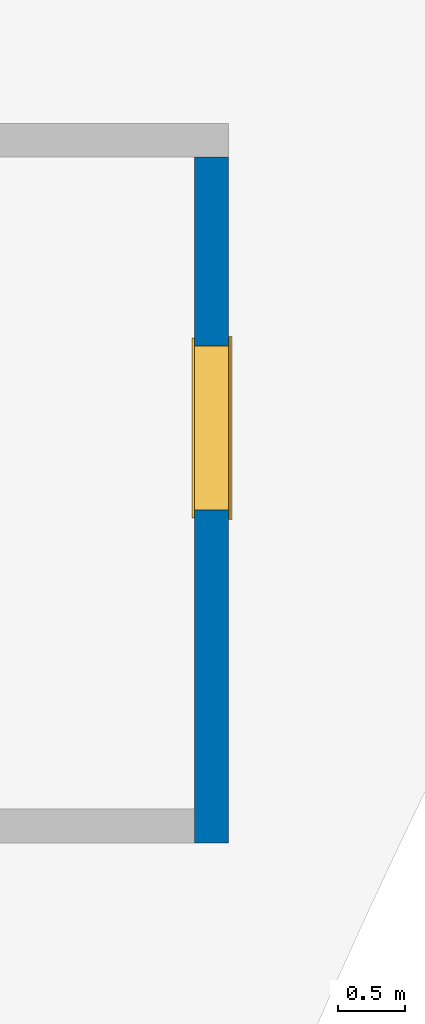
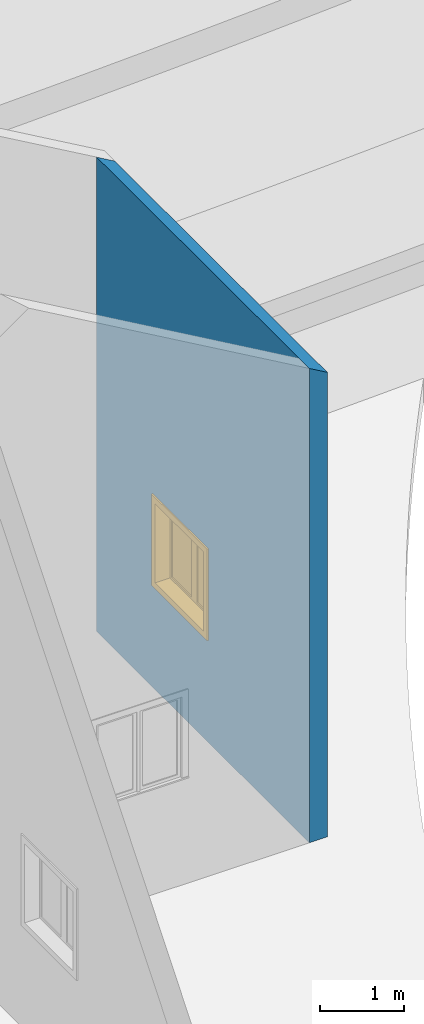
# One storey, part 11 of 39: 1 wall, 1 window, 1 opening.
"""IFC2X3 building model written with IfcOpenShell, lengths in millimetres."""

from ifc_helpers import new_model, entity, si_unit, converted_unit, derived_unit, direction, frame, frame_2d, origin, place, context, subcontext, project, spatial, polyline, rectangle, outline, extrude, clip, bounded_halfspace, source, transform, mapped, material, material_list, layer, layer_set, layer_usage, type_object, type_shapes, element, fill, save


model = new_model("IFC2X3")

# Units and contexts
model_context = context("Model", 3, precision=1e-06, world=origin(), true_north=direction((2.0, 6.12303176911189e-17, 1.0)))
context_of_model = context(None, 3, precision=1e-06, world=origin(), true_north=direction((2.0, 6.12303176911189e-17, 1.0)))
body_context = subcontext(model_context, "Body", "Model", "MODEL_VIEW")
ifc_project = project(units=[si_unit("LENGTHUNIT", "METRE", prefix="MILLI"), si_unit("AREAUNIT", "SQUARE_METRE", prefix="MILLI"), si_unit("VOLUMEUNIT", "CUBIC_METRE", prefix="MILLI"), converted_unit("PLANEANGLEUNIT", "DEGREE", entity("IfcRatioMeasure", 0.0174532925199433), si_unit("PLANEANGLEUNIT", "RADIAN"), dimensions=[0, 0, 0, 0, 0, 0, 0]), si_unit("MASSUNIT", "GRAM", prefix="KILO"), si_unit("TIMEUNIT", "SECOND"), si_unit("THERMODYNAMICTEMPERATUREUNIT", "KELVIN"), derived_unit("THERMALTRANSMITTANCEUNIT", [(si_unit("MASSUNIT", "GRAM", prefix="KILO"), 1), (si_unit("THERMODYNAMICTEMPERATUREUNIT", "KELVIN"), -1), (si_unit("TIMEUNIT", "SECOND"), -3)]), derived_unit("VOLUMETRICFLOWRATEUNIT", [(si_unit("LENGTHUNIT", "METRE"), 3), (si_unit("TIMEUNIT", "SECOND"), -1)])], contexts=[model_context, context_of_model])

# Site, building, storey
site_placement = place(None, origin())
site = spatial("IfcSite", under=ifc_project, at=site_placement, CompositionType="ELEMENT")
building_placement = place(site_placement, origin())
building = spatial("IfcBuilding", under=site, at=building_placement, CompositionType="ELEMENT")
storey_placement = place(building_placement, frame((0.0, 0.0, 4000.0)))
storey = spatial("IfcBuildingStorey", under=building, at=storey_placement, Name="Level 2", CompositionType="ELEMENT", Elevation=4000.0)

# Wall, opening, window
ifc_material_1 = material(Name="Concrete - Cast In Situ")
ifc_layer = layer(ifc_material_1, 250.0)
ifc_layer_set = layer_set([ifc_layer], Name="Basic Wall:Structure wall")
ifc_layer_usage = layer_usage(ifc_layer_set, "AXIS2", "NEGATIVE", 125.0)
wall_type = type_object("IfcWallType", Name="Basic Wall:Structure wall", PredefinedType="STANDARD", material=ifc_layer_set)
wall_placement = place(storey_placement, frame((-312846.196209224, 247689.404995702, 362.0), z_axis=(0.0, 0.0, 1.0), x_axis=(0.0, 1.0, 0.0)))
wall = element("IfcWallStandardCase", 1, at=wall_placement, inside=storey, type_object=wall_type, material=ifc_layer_usage, Name="Basic Wall:Structure wall", ObjectType="Basic Wall:Structure wall", context=body_context, shape_type="Clipping", body=[
    clip(extrude(rectangle(XDim=5088.12506521643, YDim=249.999999999978, at=frame_2d((2544.06253260822, 0.0), x_axis=(-1.0, 0.0))), origin(), (0.0, 0.0, 1.0), 8000.0), bounded_halfspace(frame((0.0, -125.0, 6782.33756729738), z_axis=(0.0, -0.499999999999959, 0.866025403784462), x_axis=(1.0, 0.0, 0.0)), False, frame((0.0, -125.0, 6782.33756729738)), polyline([(0.0, 0.0), (5088.12506521643, 0.0), (5088.12506521643, 250.0), (250.0, 250.0), (0.0, 250.0), (0.0, 0.0)]))),
])
opening_placement = place(wall_placement, frame((3688.12506521644, 125.0, 1553.0)))
opening = element("IfcOpeningElement", 2, at=opening_placement, cuts=wall, Name="M_Casement Dbl with Trim:1220 x 1220mm:1220 x 1220mm:1", ObjectType="Opening", context=body_context, shape_type="SweptSolid", body=[
    extrude(rectangle(XDim=1220.0, YDim=1220.0, at=frame_2d((610.0, 610.0), x_axis=(-1.0, 0.0))), frame((0.0, 0.0, 0.0), z_axis=(0.0, -1.0, 0.0), x_axis=(0.0, 0.0, 1.0)), (0.0, 0.0, 1.0), 250.0),
])
ifc_material_2 = material(Name="Glass")
ifc_material_3 = material(Name="Sash")
ifc_material_4 = material(Name="Trim")
ifc_material_list_1 = material_list([ifc_material_2, ifc_material_3, ifc_material_4])
ifc_material_list_2 = material_list([ifc_material_2, ifc_material_3, ifc_material_4])
window_style = type_object("IfcWindowStyle", Name="1220 x 1220mm", ConstructionType="NOTDEFINED", OperationType="NOTDEFINED", ParameterTakesPrecedence=False, Sizeable=False, material=ifc_material_list_2)
shared_shape = source(origin(), body_context, "Body", "SweptSolid", [
    extrude(rectangle(XDim=482.999999999998, YDim=12.7, at=frame_2d((0.0, -1.68753899743024e-14), x_axis=(1.0, 0.0))), frame((305.0, 246.875, 63.5000000000002), z_axis=(0.0, 0.0, 1.0), x_axis=(-1.0, 0.0, 0.0)), (0.0, 0.0, 1.0), 1093.0),
    extrude(outline(polyline([(-285.949999999999, -590.950000000002), (285.949999999999, -590.950000000002), (285.949999999999, 590.950000000003), (-285.949999999999, 590.950000000003), (-285.949999999999, -590.950000000002)]), holes=[polyline([(-241.499999999998, -546.500000000003), (-241.499999999998, 546.500000000002), (241.5, 546.500000000002), (241.5, -546.500000000003), (-241.499999999998, -546.500000000003)])]), frame((305.0, 269.1, 610.0), z_axis=(0.0, -1.0, 0.0), x_axis=(-1.0, 0.0, 0.0)), (0.0, 0.0, 1.0), 44.45),
    extrude(rectangle(XDim=1359.89999999999, YDim=25.7, at=frame_2d((0.0, -1.68753899743024e-14), x_axis=(1.0, 0.0))), frame((610.0, 300.95, 0.0), z_axis=(0.0, 0.0, 1.0), x_axis=(-1.0, 0.0, 0.0)), (0.0, 0.0, 1.0), 19.0500000000014),
    extrude(outline(polyline([(-568.700000000007, 590.949999999995), (613.200000000007, 590.949999999995), (613.200000000007, 679.949999999994), (-657.700000000005, 679.949999999994), (-657.700000000005, -679.949999999993), (613.200000000006, -679.949999999993), (613.200000000006, -590.949999999995), (-568.700000000007, -590.949999999995), (-568.700000000007, 590.949999999995)])), frame((610.0, 301.1, 632.250000000007), z_axis=(0.0, -1.0, 0.0), x_axis=(0.0, 0.0, -1.0)), (0.0, 0.0, 1.0), 13.0),
    extrude(outline(polyline([(-667.25000000001, -667.249999999998), (667.25000000001, -667.249999999998), (667.25000000001, 667.249999999998), (-667.25000000001, 667.249999999998), (-667.25000000001, -667.249999999998)]), holes=[polyline([(-578.250000000011, -578.250000000001), (-578.250000000011, 578.249999999997), (578.24999999999, 578.249999999997), (578.24999999999, -578.250000000001), (-578.250000000011, -578.250000000001)])]), frame((610.0, 38.1, 610.0), z_axis=(0.0, -1.0, 0.0), x_axis=(0.0, 0.0, -1.0)), (0.0, 0.0, 1.0), 19.0),
    extrude(rectangle(XDim=482.999999999998, YDim=12.7, at=frame_2d((4.2632564145606e-14, 0.0), x_axis=(1.0, 0.0))), frame((915.0, 246.875, 63.4999999999994)), (0.0, 0.0, 1.0), 1093.0),
    extrude(outline(polyline([(-285.949999999999, -590.950000000002), (285.949999999999, -590.950000000002), (285.949999999999, 590.950000000002), (-285.949999999999, 590.950000000002), (-285.949999999999, -590.950000000002)]), holes=[polyline([(-241.499999999999, -546.500000000003), (-241.499999999999, 546.500000000001), (241.499999999999, 546.500000000001), (241.499999999999, -546.500000000003), (-241.499999999999, -546.500000000003)])]), frame((915.0, 269.1, 610.0), z_axis=(0.0, -1.0, 0.0), x_axis=(-1.0, 0.0, 0.0)), (0.0, 0.0, 1.0), 44.45),
    extrude(outline(polyline([(-610.0, -610.0), (610.0, -610.0), (610.0, 610.0), (-610.0, 610.0), (-610.0, -610.0)]), holes=[polyline([(-578.25, -578.250000000001), (-578.25, 578.25), (578.249999999997, 578.25), (578.249999999997, -578.250000000001), (-578.25, -578.250000000001)])]), frame((610.0, 224.65, 610.0), z_axis=(0.0, -1.0, 0.0), x_axis=(-1.0, 0.0, 0.0)), (0.0, 0.0, 1.0), 186.55),
    extrude(outline(polyline([(-610.0, -610.0), (610.0, -610.0), (610.0, 610.0), (-610.0, 610.0), (-610.0, -610.0)]), holes=[polyline([(-590.950000000002, -590.949999999996), (-590.950000000002, 590.95), (590.950000000003, 590.95), (590.950000000003, -590.949999999996), (-590.950000000002, -590.949999999996)])]), frame((610.0, 288.1, 610.0), z_axis=(0.0, -1.0, 0.0), x_axis=(0.0, 0.0, -1.0)), (0.0, 0.0, 1.0), 63.45),
    extrude(rectangle(XDim=38.0999999999998, YDim=63.5, at=frame_2d((0.0, -8.88178419700125e-15), x_axis=(1.0, 0.0))), frame((610.0, 256.4, 19.0499999999995)), (0.0, 0.0, 1.0), 1181.90000000001),
])
type_shapes(window_style, [shared_shape])
window_placement = place(opening_placement, frame((0.0, 38.0999999999767, 0.0), z_axis=(0.0, 0.0, 1.0), x_axis=(-1.0, 0.0, 0.0)))
window = element("IfcWindow", 3, at=window_placement, inside=storey, type_object=window_style, material=ifc_material_list_1, Name="M_Casement Dbl with Trim:1220 x 1220mm", ObjectType="1220 x 1220mm", OverallHeight=1220.0, OverallWidth=1220.0, context=body_context, shape_type="MappedRepresentation", body=[
    mapped(shared_shape, transform((0.0, 0.0, 0.0), scale=1.0)),
])
fill(opening, window)

save(model, "model.ifc")
